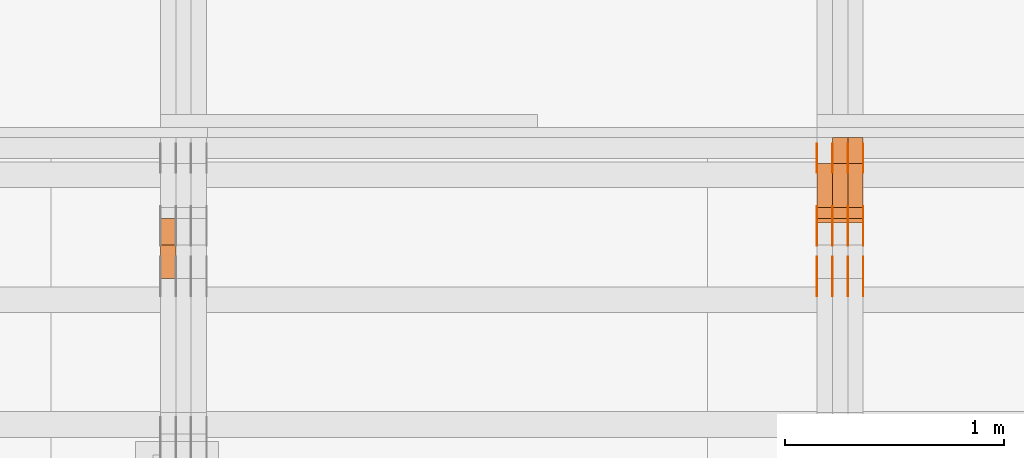
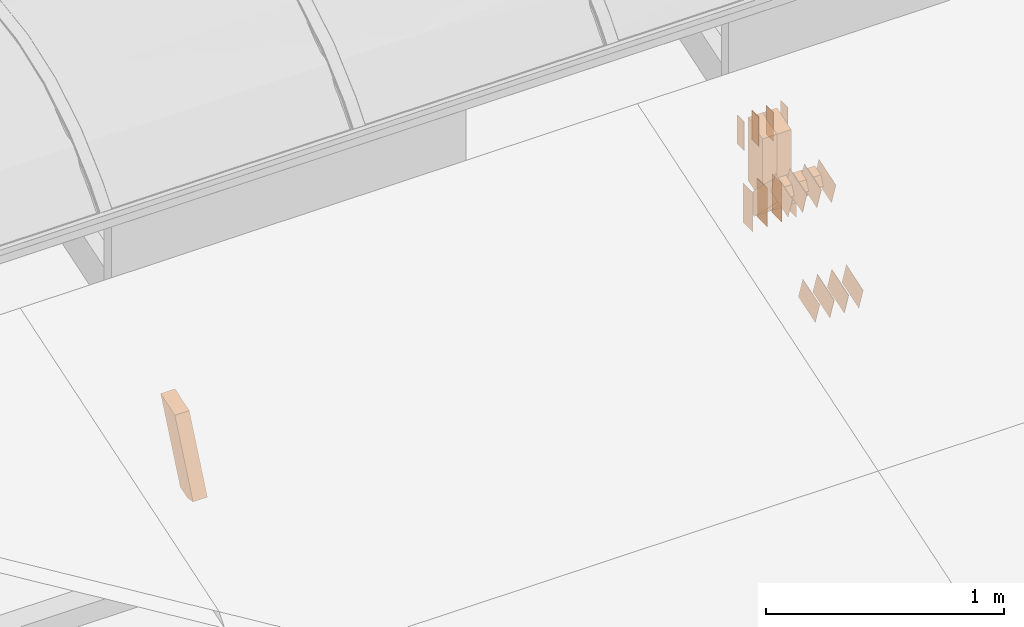
# One storey, part 157 of 385: 30 proxies.
"""IFC2X3 building model written with IfcOpenShell, lengths in millimetres."""

from ifc_helpers import new_model, entity, si_unit, converted_unit, derived_unit, direction, frame, frame_2d, origin, origin_2d_with_axis, place, context, subcontext, project, spatial, polyline, rectangle, outline, extrude, source, transform, mapped, material, type_object, type_shapes, element, save


model = new_model("IFC2X3")

# Units and contexts
model_context = context("Model", 3, precision=0.01, world=origin(), true_north=direction((6.12303176911189e-17, 1.0)))
body_context = subcontext(model_context, "Body", "Model", "MODEL_VIEW")
ifc_project = project(units=[si_unit("LENGTHUNIT", "METRE", prefix="MILLI"), si_unit("AREAUNIT", "SQUARE_METRE"), si_unit("VOLUMEUNIT", "CUBIC_METRE"), converted_unit("PLANEANGLEUNIT", "DEGREE", entity("IfcRatioMeasure", 0.0174532925199433), si_unit("PLANEANGLEUNIT", "RADIAN"), dimensions=[0, 0, 0, 0, 0, 0, 0]), si_unit("MASSUNIT", "GRAM", prefix="KILO"), derived_unit("MASSDENSITYUNIT", [(si_unit("MASSUNIT", "GRAM", prefix="KILO"), 1), (si_unit("LENGTHUNIT", "METRE"), -3)]), si_unit("TIMEUNIT", "SECOND"), si_unit("FREQUENCYUNIT", "HERTZ"), si_unit("THERMODYNAMICTEMPERATUREUNIT", "DEGREE_CELSIUS"), derived_unit("THERMALTRANSMITTANCEUNIT", [(si_unit("MASSUNIT", "GRAM", prefix="KILO"), 1), (si_unit("THERMODYNAMICTEMPERATUREUNIT", "KELVIN"), -1), (si_unit("TIMEUNIT", "SECOND"), -3)]), derived_unit("VOLUMETRICFLOWRATEUNIT", [(si_unit("LENGTHUNIT", "METRE"), 3), (si_unit("TIMEUNIT", "SECOND"), -1)]), si_unit("ELECTRICCURRENTUNIT", "AMPERE"), si_unit("ELECTRICVOLTAGEUNIT", "VOLT"), si_unit("POWERUNIT", "WATT"), si_unit("FORCEUNIT", "NEWTON", prefix="KILO"), si_unit("ILLUMINANCEUNIT", "LUX"), si_unit("LUMINOUSFLUXUNIT", "LUMEN"), si_unit("LUMINOUSINTENSITYUNIT", "CANDELA"), derived_unit("USERDEFINED", [(si_unit("MASSUNIT", "GRAM", prefix="KILO"), -1), (si_unit("LENGTHUNIT", "METRE"), -2), (si_unit("TIMEUNIT", "SECOND"), 3), (si_unit("LUMINOUSFLUXUNIT", "LUMEN"), 1)]), derived_unit("LINEARVELOCITYUNIT", [(si_unit("LENGTHUNIT", "METRE"), 1), (si_unit("TIMEUNIT", "SECOND"), -1)]), si_unit("PRESSUREUNIT", "PASCAL"), derived_unit("USERDEFINED", [(si_unit("LENGTHUNIT", "METRE"), -2), (si_unit("MASSUNIT", "GRAM", prefix="KILO"), 1), (si_unit("TIMEUNIT", "SECOND"), -2)])], contexts=[model_context])

# Site, building, storey
site_placement = place(None, origin())
site = spatial("IfcSite", under=ifc_project, at=site_placement, CompositionType="ELEMENT")
building_placement = place(site_placement, origin())
building = spatial("IfcBuilding", under=site, at=building_placement, CompositionType="ELEMENT")
storey_placement = place(building_placement, origin())
storey = spatial("IfcBuildingStorey", under=building, at=storey_placement, Name="Default", CompositionType="ELEMENT", Elevation=0.0)

# Proxies
ifc_material_1 = material(Name="IfcSurfaceStyle #346868")
building_element_proxy_type_1 = type_object("IfcBuildingElementProxyType", PredefinedType="NOTDEFINED", material=ifc_material_1)
shared_shape_1 = source(origin(), body_context, "Body", "SweptSolid", [
    extrude(rectangle(XDim=200.0, YDim=84.0, at=frame_2d((0.0, -7.105427357601e-15), x_axis=(1.0, 0.0))), frame((100.0, 42.0, 0.0), z_axis=(0.0, 0.0, 1.0), x_axis=(-1.0, 0.0, 0.0)), (0.0, 0.0, 1.0), 1.3),
])
type_shapes(building_element_proxy_type_1, [shared_shape_1])
proxy_1_placement = place(building_placement, frame((27386.3, 13702.0, 3651.4150390625), z_axis=(-1.0, 0.0, 0.0), x_axis=(0.0, 0.0, -1.0)))
element("IfcBuildingElementProxy", 1, at=proxy_1_placement, inside=storey, type_object=building_element_proxy_type_1, material=ifc_material_1, context=body_context, shape_type="MappedRepresentation", body=[
    mapped(shared_shape_1, transform((0.0, 0.0, 0.0), scale=1.0)),
])
ifc_material_2 = material(Name="IfcSurfaceStyle #346811")
building_element_proxy_type_2 = type_object("IfcBuildingElementProxyType", PredefinedType="NOTDEFINED", material=ifc_material_2)
shared_shape_2 = source(origin(), body_context, "Body", "SweptSolid", [
    extrude(rectangle(XDim=200.0, YDim=84.0, at=frame_2d((0.0, -7.105427357601e-15), x_axis=(1.0, 0.0))), frame((100.0, 42.0, 0.0), z_axis=(0.0, 0.0, 1.0), x_axis=(-1.0, 0.0, 0.0)), (0.0, 0.0, 1.0), 1.3),
])
type_shapes(building_element_proxy_type_2, [shared_shape_2])
proxy_2_placement = place(building_placement, frame((27315.0, 13702.0, 3651.4150390625), z_axis=(-1.0, 0.0, 0.0), x_axis=(0.0, 0.0, -1.0)))
element("IfcBuildingElementProxy", 2, at=proxy_2_placement, inside=storey, type_object=building_element_proxy_type_2, material=ifc_material_2, context=body_context, shape_type="MappedRepresentation", body=[
    mapped(shared_shape_2, transform((0.0, 0.0, 0.0), scale=1.0)),
])
ifc_material_3 = material(Name="IfcSurfaceStyle #346754")
building_element_proxy_type_3 = type_object("IfcBuildingElementProxyType", PredefinedType="NOTDEFINED", material=ifc_material_3)
shared_shape_3 = source(origin(), body_context, "Body", "SweptSolid", [
    extrude(rectangle(XDim=200.0, YDim=84.0, at=frame_2d((0.0, -7.105427357601e-15), x_axis=(1.0, 0.0))), frame((100.0, 42.0, 0.0), z_axis=(0.0, 0.0, 1.0), x_axis=(-1.0, 0.0, 0.0)), (0.0, 0.0, 1.0), 1.3),
])
type_shapes(building_element_proxy_type_3, [shared_shape_3])
proxy_3_placement = place(building_placement, frame((27316.3, 13702.0, 3651.4150390625), z_axis=(-1.0, 0.0, 0.0), x_axis=(0.0, 0.0, -1.0)))
element("IfcBuildingElementProxy", 3, at=proxy_3_placement, inside=storey, type_object=building_element_proxy_type_3, material=ifc_material_3, context=body_context, shape_type="MappedRepresentation", body=[
    mapped(shared_shape_3, transform((0.0, 0.0, 0.0), scale=1.0)),
])
ifc_material_4 = material(Name="IfcSurfaceStyle #346697")
building_element_proxy_type_4 = type_object("IfcBuildingElementProxyType", PredefinedType="NOTDEFINED", material=ifc_material_4)
shared_shape_4 = source(origin(), body_context, "Body", "SweptSolid", [
    extrude(rectangle(XDim=200.0, YDim=84.0, at=frame_2d((0.0, -7.105427357601e-15), x_axis=(1.0, 0.0))), frame((100.0, 42.0, 0.0), z_axis=(0.0, 0.0, 1.0), x_axis=(-1.0, 0.0, 0.0)), (0.0, 0.0, 1.0), 1.29999999999998),
])
type_shapes(building_element_proxy_type_4, [shared_shape_4])
proxy_4_placement = place(building_placement, frame((27245.0, 13702.0, 3651.4150390625), z_axis=(-1.0, 0.0, 0.0), x_axis=(0.0, 0.0, -1.0)))
element("IfcBuildingElementProxy", 4, at=proxy_4_placement, inside=storey, type_object=building_element_proxy_type_4, material=ifc_material_4, context=body_context, shape_type="MappedRepresentation", body=[
    mapped(shared_shape_4, transform((0.0, 0.0, 0.0), scale=1.0)),
])
ifc_material_5 = material(Name="IfcSurfaceStyle #346640")
building_element_proxy_type_5 = type_object("IfcBuildingElementProxyType", PredefinedType="NOTDEFINED", material=ifc_material_5)
shared_shape_5 = source(origin(), body_context, "Body", "SweptSolid", [
    extrude(rectangle(XDim=200.0, YDim=84.0, at=frame_2d((0.0, -7.105427357601e-15), x_axis=(1.0, 0.0))), frame((100.0, 42.0, 0.0), z_axis=(0.0, 0.0, 1.0), x_axis=(-1.0, 0.0, 0.0)), (0.0, 0.0, 1.0), 1.29999999999998),
])
type_shapes(building_element_proxy_type_5, [shared_shape_5])
proxy_5_placement = place(building_placement, frame((27246.3, 13702.0, 3651.4150390625), z_axis=(-1.0, 0.0, 0.0), x_axis=(0.0, 0.0, -1.0)))
element("IfcBuildingElementProxy", 5, at=proxy_5_placement, inside=storey, type_object=building_element_proxy_type_5, material=ifc_material_5, context=body_context, shape_type="MappedRepresentation", body=[
    mapped(shared_shape_5, transform((0.0, 0.0, 0.0), scale=1.0)),
])
ifc_material_6 = material(Name="IfcSurfaceStyle #346583")
building_element_proxy_type_6 = type_object("IfcBuildingElementProxyType", PredefinedType="NOTDEFINED", material=ifc_material_6)
shared_shape_6 = source(origin(), body_context, "Body", "SweptSolid", [
    extrude(rectangle(XDim=200.0, YDim=84.0, at=frame_2d((0.0, -7.105427357601e-15), x_axis=(1.0, 0.0))), frame((100.0, 42.0, 0.0), z_axis=(0.0, 0.0, 1.0), x_axis=(-1.0, 0.0, 0.0)), (0.0, 0.0, 1.0), 1.29999999999999),
])
type_shapes(building_element_proxy_type_6, [shared_shape_6])
proxy_6_placement = place(building_placement, frame((27175.0, 13702.0, 3651.4150390625), z_axis=(-1.0, 0.0, 0.0), x_axis=(0.0, 0.0, -1.0)))
element("IfcBuildingElementProxy", 6, at=proxy_6_placement, inside=storey, type_object=building_element_proxy_type_6, material=ifc_material_6, context=body_context, shape_type="MappedRepresentation", body=[
    mapped(shared_shape_6, transform((0.0, 0.0, 0.0), scale=1.0)),
])
ifc_material_7 = material(Name="IfcSurfaceStyle #346526")
building_element_proxy_type_7 = type_object("IfcBuildingElementProxyType", PredefinedType="NOTDEFINED", material=ifc_material_7)
shared_shape_7 = source(origin(), body_context, "Body", "SweptSolid", [
    extrude(outline(polyline([(-75.0003398116828, -59.9998507501386), (75.0003249421766, -59.9998507501386), (75.0003398116837, 59.9998507501387), (-75.0003249421775, 59.9998507501387), (-75.0003398116828, -59.9998507501386)])), frame((75.0003398116837, 60.0000773549637, 0.0), z_axis=(0.0, 0.0, 1.0), x_axis=(-1.0, 0.0, 0.0)), (0.0, 0.0, 1.0), 1.3),
])
type_shapes(building_element_proxy_type_7, [shared_shape_7])
proxy_7_placement = place(building_placement, frame((27386.3, 13054.73046875, 3417.8388671875), z_axis=(-1.0, 0.0, 0.0), x_axis=(0.0, 0.951056516295124, 0.309016994375039)))
element("IfcBuildingElementProxy", 7, at=proxy_7_placement, inside=storey, type_object=building_element_proxy_type_7, material=ifc_material_7, context=body_context, shape_type="MappedRepresentation", body=[
    mapped(shared_shape_7, transform((0.0, 0.0, 0.0), scale=1.0)),
])
ifc_material_8 = material(Name="IfcSurfaceStyle #346469")
building_element_proxy_type_8 = type_object("IfcBuildingElementProxyType", PredefinedType="NOTDEFINED", material=ifc_material_8)
shared_shape_8 = source(origin(), body_context, "Body", "SweptSolid", [
    extrude(outline(polyline([(-75.0003398116828, -59.9998507501386), (75.0003249421766, -59.9998507501386), (75.0003398116837, 59.9998507501387), (-75.0003249421775, 59.9998507501387), (-75.0003398116828, -59.9998507501386)])), frame((75.0003398116837, 60.0000773549637, 0.0), z_axis=(0.0, 0.0, 1.0), x_axis=(-1.0, 0.0, 0.0)), (0.0, 0.0, 1.0), 1.3),
])
type_shapes(building_element_proxy_type_8, [shared_shape_8])
proxy_8_placement = place(building_placement, frame((27315.0, 13054.73046875, 3417.8388671875), z_axis=(-1.0, 0.0, 0.0), x_axis=(0.0, 0.951056516295124, 0.309016994375039)))
element("IfcBuildingElementProxy", 8, at=proxy_8_placement, inside=storey, type_object=building_element_proxy_type_8, material=ifc_material_8, context=body_context, shape_type="MappedRepresentation", body=[
    mapped(shared_shape_8, transform((0.0, 0.0, 0.0), scale=1.0)),
])
ifc_material_9 = material(Name="IfcSurfaceStyle #346412")
building_element_proxy_type_9 = type_object("IfcBuildingElementProxyType", PredefinedType="NOTDEFINED", material=ifc_material_9)
shared_shape_9 = source(origin(), body_context, "Body", "SweptSolid", [
    extrude(outline(polyline([(-75.0003398116828, -59.9998507501386), (75.0003249421766, -59.9998507501386), (75.0003398116837, 59.9998507501387), (-75.0003249421775, 59.9998507501387), (-75.0003398116828, -59.9998507501386)])), frame((75.0003398116837, 60.0000773549637, 0.0), z_axis=(0.0, 0.0, 1.0), x_axis=(-1.0, 0.0, 0.0)), (0.0, 0.0, 1.0), 1.3),
])
type_shapes(building_element_proxy_type_9, [shared_shape_9])
proxy_9_placement = place(building_placement, frame((27316.3, 13054.73046875, 3417.8388671875), z_axis=(-1.0, 0.0, 0.0), x_axis=(0.0, 0.951056516295124, 0.309016994375039)))
element("IfcBuildingElementProxy", 9, at=proxy_9_placement, inside=storey, type_object=building_element_proxy_type_9, material=ifc_material_9, context=body_context, shape_type="MappedRepresentation", body=[
    mapped(shared_shape_9, transform((0.0, 0.0, 0.0), scale=1.0)),
])
ifc_material_10 = material(Name="IfcSurfaceStyle #346355")
building_element_proxy_type_10 = type_object("IfcBuildingElementProxyType", PredefinedType="NOTDEFINED", material=ifc_material_10)
shared_shape_10 = source(origin(), body_context, "Body", "SweptSolid", [
    extrude(outline(polyline([(-75.0003398116828, -59.9998507501386), (75.0003249421766, -59.9998507501386), (75.0003398116837, 59.9998507501387), (-75.0003249421775, 59.9998507501387), (-75.0003398116828, -59.9998507501386)])), frame((75.0003398116837, 60.0000773549637, 0.0), z_axis=(0.0, 0.0, 1.0), x_axis=(-1.0, 0.0, 0.0)), (0.0, 0.0, 1.0), 1.29999999999999),
])
type_shapes(building_element_proxy_type_10, [shared_shape_10])
proxy_10_placement = place(building_placement, frame((27245.0, 13054.73046875, 3417.8388671875), z_axis=(-1.0, 0.0, 0.0), x_axis=(0.0, 0.951056516295124, 0.309016994375039)))
element("IfcBuildingElementProxy", 10, at=proxy_10_placement, inside=storey, type_object=building_element_proxy_type_10, material=ifc_material_10, context=body_context, shape_type="MappedRepresentation", body=[
    mapped(shared_shape_10, transform((0.0, 0.0, 0.0), scale=1.0)),
])
ifc_material_11 = material(Name="IfcSurfaceStyle #346298")
building_element_proxy_type_11 = type_object("IfcBuildingElementProxyType", PredefinedType="NOTDEFINED", material=ifc_material_11)
shared_shape_11 = source(origin(), body_context, "Body", "SweptSolid", [
    extrude(outline(polyline([(-75.0003398116828, -59.9998507501386), (75.0003249421766, -59.9998507501386), (75.0003398116837, 59.9998507501387), (-75.0003249421775, 59.9998507501387), (-75.0003398116828, -59.9998507501386)])), frame((75.0003398116837, 60.0000773549637, 0.0), z_axis=(0.0, 0.0, 1.0), x_axis=(-1.0, 0.0, 0.0)), (0.0, 0.0, 1.0), 1.29999999999999),
])
type_shapes(building_element_proxy_type_11, [shared_shape_11])
proxy_11_placement = place(building_placement, frame((27246.3, 13054.73046875, 3417.8388671875), z_axis=(-1.0, 0.0, 0.0), x_axis=(0.0, 0.951056516295124, 0.309016994375039)))
element("IfcBuildingElementProxy", 11, at=proxy_11_placement, inside=storey, type_object=building_element_proxy_type_11, material=ifc_material_11, context=body_context, shape_type="MappedRepresentation", body=[
    mapped(shared_shape_11, transform((0.0, 0.0, 0.0), scale=1.0)),
])
ifc_material_12 = material(Name="IfcSurfaceStyle #346241")
building_element_proxy_type_12 = type_object("IfcBuildingElementProxyType", PredefinedType="NOTDEFINED", material=ifc_material_12)
shared_shape_12 = source(origin(), body_context, "Body", "SweptSolid", [
    extrude(outline(polyline([(-75.0003398116828, -59.9998507501386), (75.0003249421766, -59.9998507501386), (75.0003398116837, 59.9998507501387), (-75.0003249421775, 59.9998507501387), (-75.0003398116828, -59.9998507501386)])), frame((75.0003398116837, 60.0000773549637, 0.0), z_axis=(0.0, 0.0, 1.0), x_axis=(-1.0, 0.0, 0.0)), (0.0, 0.0, 1.0), 1.29999999999999),
])
type_shapes(building_element_proxy_type_12, [shared_shape_12])
proxy_12_placement = place(building_placement, frame((27175.0, 13054.73046875, 3417.8388671875), z_axis=(-1.0, 0.0, 0.0), x_axis=(0.0, 0.951056516295124, 0.309016994375039)))
element("IfcBuildingElementProxy", 12, at=proxy_12_placement, inside=storey, type_object=building_element_proxy_type_12, material=ifc_material_12, context=body_context, shape_type="MappedRepresentation", body=[
    mapped(shared_shape_12, transform((0.0, 0.0, 0.0), scale=1.0)),
])
ifc_material_13 = material(Name="IfcSurfaceStyle #338660")
building_element_proxy_type_13 = type_object("IfcBuildingElementProxyType", PredefinedType="NOTDEFINED", material=ifc_material_13)
shared_shape_13 = source(origin(), body_context, "Body", "SweptSolid", [
    extrude(outline(polyline([(-74.999875428623, -60.0000016373506), (74.9998605591059, -60.0000016373506), (74.9998754286239, 60.0000016373506), (-74.9998605591068, 60.0000016373506), (-74.999875428623, -60.0000016373506)])), frame((75.0002691827262, 60.0000190504561, 0.0), z_axis=(0.0, 0.0, 1.0), x_axis=(-1.0, 0.0, 0.0)), (0.0, 0.0, 1.0), 1.3),
])
type_shapes(building_element_proxy_type_13, [shared_shape_13])
proxy_13_placement = place(building_placement, frame((27386.3, 13285.0865109705, 3819.37496637467), z_axis=(-1.0, 0.0, 0.0), x_axis=(0.0, 0.951056516295154, 0.309016994374948)))
element("IfcBuildingElementProxy", 13, at=proxy_13_placement, inside=storey, type_object=building_element_proxy_type_13, material=ifc_material_13, context=body_context, shape_type="MappedRepresentation", body=[
    mapped(shared_shape_13, transform((0.0, 0.0, 0.0), scale=1.0)),
])
ifc_material_14 = material(Name="IfcSurfaceStyle #338603")
building_element_proxy_type_14 = type_object("IfcBuildingElementProxyType", PredefinedType="NOTDEFINED", material=ifc_material_14)
shared_shape_14 = source(origin(), body_context, "Body", "SweptSolid", [
    extrude(outline(polyline([(-74.999875428623, -60.0000016373506), (74.9998605591059, -60.0000016373506), (74.9998754286239, 60.0000016373506), (-74.9998605591068, 60.0000016373506), (-74.999875428623, -60.0000016373506)])), frame((75.0002691827262, 60.0000190504561, 0.0), z_axis=(0.0, 0.0, 1.0), x_axis=(-1.0, 0.0, 0.0)), (0.0, 0.0, 1.0), 1.3),
])
type_shapes(building_element_proxy_type_14, [shared_shape_14])
proxy_14_placement = place(building_placement, frame((27315.0, 13285.0865109705, 3819.37496637467), z_axis=(-1.0, 0.0, 0.0), x_axis=(0.0, 0.951056516295154, 0.309016994374948)))
element("IfcBuildingElementProxy", 14, at=proxy_14_placement, inside=storey, type_object=building_element_proxy_type_14, material=ifc_material_14, context=body_context, shape_type="MappedRepresentation", body=[
    mapped(shared_shape_14, transform((0.0, 0.0, 0.0), scale=1.0)),
])
ifc_material_15 = material(Name="IfcSurfaceStyle #338546")
building_element_proxy_type_15 = type_object("IfcBuildingElementProxyType", PredefinedType="NOTDEFINED", material=ifc_material_15)
shared_shape_15 = source(origin(), body_context, "Body", "SweptSolid", [
    extrude(outline(polyline([(-74.999875428623, -60.0000016373506), (74.9998605591059, -60.0000016373506), (74.9998754286239, 60.0000016373506), (-74.9998605591068, 60.0000016373506), (-74.999875428623, -60.0000016373506)])), frame((75.0002691827262, 60.0000190504561, 0.0), z_axis=(0.0, 0.0, 1.0), x_axis=(-1.0, 0.0, 0.0)), (0.0, 0.0, 1.0), 1.3),
])
type_shapes(building_element_proxy_type_15, [shared_shape_15])
proxy_15_placement = place(building_placement, frame((27316.3, 13285.0865109705, 3819.37496637467), z_axis=(-1.0, 0.0, 0.0), x_axis=(0.0, 0.951056516295154, 0.309016994374948)))
element("IfcBuildingElementProxy", 15, at=proxy_15_placement, inside=storey, type_object=building_element_proxy_type_15, material=ifc_material_15, context=body_context, shape_type="MappedRepresentation", body=[
    mapped(shared_shape_15, transform((0.0, 0.0, 0.0), scale=1.0)),
])
ifc_material_16 = material(Name="IfcSurfaceStyle #338489")
building_element_proxy_type_16 = type_object("IfcBuildingElementProxyType", PredefinedType="NOTDEFINED", material=ifc_material_16)
shared_shape_16 = source(origin(), body_context, "Body", "SweptSolid", [
    extrude(outline(polyline([(-74.999875428623, -60.0000016373506), (74.9998605591059, -60.0000016373506), (74.9998754286239, 60.0000016373506), (-74.9998605591068, 60.0000016373506), (-74.999875428623, -60.0000016373506)])), frame((75.0002691827262, 60.0000190504561, 0.0), z_axis=(0.0, 0.0, 1.0), x_axis=(-1.0, 0.0, 0.0)), (0.0, 0.0, 1.0), 1.29999999999999),
])
type_shapes(building_element_proxy_type_16, [shared_shape_16])
proxy_16_placement = place(building_placement, frame((27245.0, 13285.0865109705, 3819.37496637467), z_axis=(-1.0, 0.0, 0.0), x_axis=(0.0, 0.951056516295154, 0.309016994374948)))
element("IfcBuildingElementProxy", 16, at=proxy_16_placement, inside=storey, type_object=building_element_proxy_type_16, material=ifc_material_16, context=body_context, shape_type="MappedRepresentation", body=[
    mapped(shared_shape_16, transform((0.0, 0.0, 0.0), scale=1.0)),
])
ifc_material_17 = material(Name="IfcSurfaceStyle #338432")
building_element_proxy_type_17 = type_object("IfcBuildingElementProxyType", PredefinedType="NOTDEFINED", material=ifc_material_17)
shared_shape_17 = source(origin(), body_context, "Body", "SweptSolid", [
    extrude(outline(polyline([(-74.999875428623, -60.0000016373506), (74.9998605591059, -60.0000016373506), (74.9998754286239, 60.0000016373506), (-74.9998605591068, 60.0000016373506), (-74.999875428623, -60.0000016373506)])), frame((75.0002691827262, 60.0000190504561, 0.0), z_axis=(0.0, 0.0, 1.0), x_axis=(-1.0, 0.0, 0.0)), (0.0, 0.0, 1.0), 1.29999999999999),
])
type_shapes(building_element_proxy_type_17, [shared_shape_17])
proxy_17_placement = place(building_placement, frame((27246.3, 13285.0865109705, 3819.37496637467), z_axis=(-1.0, 0.0, 0.0), x_axis=(0.0, 0.951056516295154, 0.309016994374948)))
element("IfcBuildingElementProxy", 17, at=proxy_17_placement, inside=storey, type_object=building_element_proxy_type_17, material=ifc_material_17, context=body_context, shape_type="MappedRepresentation", body=[
    mapped(shared_shape_17, transform((0.0, 0.0, 0.0), scale=1.0)),
])
ifc_material_18 = material(Name="IfcSurfaceStyle #338375")
building_element_proxy_type_18 = type_object("IfcBuildingElementProxyType", PredefinedType="NOTDEFINED", material=ifc_material_18)
shared_shape_18 = source(origin(), body_context, "Body", "SweptSolid", [
    extrude(outline(polyline([(-74.999875428623, -60.0000016373506), (74.9998605591059, -60.0000016373506), (74.9998754286239, 60.0000016373506), (-74.9998605591068, 60.0000016373506), (-74.999875428623, -60.0000016373506)])), frame((75.0002691827262, 60.0000190504561, 0.0), z_axis=(0.0, 0.0, 1.0), x_axis=(-1.0, 0.0, 0.0)), (0.0, 0.0, 1.0), 1.29999999999999),
])
type_shapes(building_element_proxy_type_18, [shared_shape_18])
proxy_18_placement = place(building_placement, frame((27175.0, 13285.0865109705, 3819.37496637467), z_axis=(-1.0, 0.0, 0.0), x_axis=(0.0, 0.951056516295154, 0.309016994374948)))
element("IfcBuildingElementProxy", 18, at=proxy_18_placement, inside=storey, type_object=building_element_proxy_type_18, material=ifc_material_18, context=body_context, shape_type="MappedRepresentation", body=[
    mapped(shared_shape_18, transform((0.0, 0.0, 0.0), scale=1.0)),
])
ifc_material_19 = material(Name="IfcSurfaceStyle #337976")
building_element_proxy_type_19 = type_object("IfcBuildingElementProxyType", PredefinedType="NOTDEFINED", material=ifc_material_19)
shared_shape_19 = source(origin(), body_context, "Body", "SweptSolid", [
    extrude(rectangle(XDim=150.0, YDim=60.0, at=origin_2d_with_axis()), frame((75.0000705696166, 30.0, 0.0), z_axis=(0.0, 0.0, 1.0), x_axis=(-1.0, 0.0, 0.0)), (0.0, 0.0, 1.0), 1.3),
])
type_shapes(building_element_proxy_type_19, [shared_shape_19])
proxy_19_placement = place(building_placement, frame((27386.3, 13750.0, 3972.59919166337), z_axis=(-1.0, 0.0, 0.0), x_axis=(0.0, 0.0, -1.0)))
element("IfcBuildingElementProxy", 19, at=proxy_19_placement, inside=storey, type_object=building_element_proxy_type_19, material=ifc_material_19, context=body_context, shape_type="MappedRepresentation", body=[
    mapped(shared_shape_19, transform((0.0, 0.0, 0.0), scale=1.0)),
])
ifc_material_20 = material(Name="IfcSurfaceStyle #337919")
building_element_proxy_type_20 = type_object("IfcBuildingElementProxyType", PredefinedType="NOTDEFINED", material=ifc_material_20)
shared_shape_20 = source(origin(), body_context, "Body", "SweptSolid", [
    extrude(rectangle(XDim=150.0, YDim=60.0, at=origin_2d_with_axis()), frame((75.0000705696166, 30.0, 0.0), z_axis=(0.0, 0.0, 1.0), x_axis=(-1.0, 0.0, 0.0)), (0.0, 0.0, 1.0), 1.3),
])
type_shapes(building_element_proxy_type_20, [shared_shape_20])
proxy_20_placement = place(building_placement, frame((27315.0, 13750.0, 3972.59919166337), z_axis=(-1.0, 0.0, 0.0), x_axis=(0.0, 0.0, -1.0)))
element("IfcBuildingElementProxy", 20, at=proxy_20_placement, inside=storey, type_object=building_element_proxy_type_20, material=ifc_material_20, context=body_context, shape_type="MappedRepresentation", body=[
    mapped(shared_shape_20, transform((0.0, 0.0, 0.0), scale=1.0)),
])
ifc_material_21 = material(Name="IfcSurfaceStyle #337862")
building_element_proxy_type_21 = type_object("IfcBuildingElementProxyType", PredefinedType="NOTDEFINED", material=ifc_material_21)
shared_shape_21 = source(origin(), body_context, "Body", "SweptSolid", [
    extrude(rectangle(XDim=150.0, YDim=60.0, at=origin_2d_with_axis()), frame((75.0000705696166, 30.0, 0.0), z_axis=(0.0, 0.0, 1.0), x_axis=(-1.0, 0.0, 0.0)), (0.0, 0.0, 1.0), 1.3),
])
type_shapes(building_element_proxy_type_21, [shared_shape_21])
proxy_21_placement = place(building_placement, frame((27316.3, 13750.0, 3972.59919166337), z_axis=(-1.0, 0.0, 0.0), x_axis=(0.0, 0.0, -1.0)))
element("IfcBuildingElementProxy", 21, at=proxy_21_placement, inside=storey, type_object=building_element_proxy_type_21, material=ifc_material_21, context=body_context, shape_type="MappedRepresentation", body=[
    mapped(shared_shape_21, transform((0.0, 0.0, 0.0), scale=1.0)),
])
ifc_material_22 = material(Name="IfcSurfaceStyle #337805")
building_element_proxy_type_22 = type_object("IfcBuildingElementProxyType", PredefinedType="NOTDEFINED", material=ifc_material_22)
shared_shape_22 = source(origin(), body_context, "Body", "SweptSolid", [
    extrude(rectangle(XDim=150.0, YDim=60.0, at=origin_2d_with_axis()), frame((75.0000705696166, 30.0, 0.0), z_axis=(0.0, 0.0, 1.0), x_axis=(-1.0, 0.0, 0.0)), (0.0, 0.0, 1.0), 1.29999999999999),
])
type_shapes(building_element_proxy_type_22, [shared_shape_22])
proxy_22_placement = place(building_placement, frame((27245.0, 13750.0, 3972.59919166337), z_axis=(-1.0, 0.0, 0.0), x_axis=(0.0, 0.0, -1.0)))
element("IfcBuildingElementProxy", 22, at=proxy_22_placement, inside=storey, type_object=building_element_proxy_type_22, material=ifc_material_22, context=body_context, shape_type="MappedRepresentation", body=[
    mapped(shared_shape_22, transform((0.0, 0.0, 0.0), scale=1.0)),
])
ifc_material_23 = material(Name="IfcSurfaceStyle #337748")
building_element_proxy_type_23 = type_object("IfcBuildingElementProxyType", PredefinedType="NOTDEFINED", material=ifc_material_23)
shared_shape_23 = source(origin(), body_context, "Body", "SweptSolid", [
    extrude(rectangle(XDim=150.0, YDim=60.0, at=origin_2d_with_axis()), frame((75.0000705696166, 30.0, 0.0), z_axis=(0.0, 0.0, 1.0), x_axis=(-1.0, 0.0, 0.0)), (0.0, 0.0, 1.0), 1.29999999999999),
])
type_shapes(building_element_proxy_type_23, [shared_shape_23])
proxy_23_placement = place(building_placement, frame((27246.3, 13750.0, 3972.59919166337), z_axis=(-1.0, 0.0, 0.0), x_axis=(0.0, 0.0, -1.0)))
element("IfcBuildingElementProxy", 23, at=proxy_23_placement, inside=storey, type_object=building_element_proxy_type_23, material=ifc_material_23, context=body_context, shape_type="MappedRepresentation", body=[
    mapped(shared_shape_23, transform((0.0, 0.0, 0.0), scale=1.0)),
])
ifc_material_24 = material(Name="IfcSurfaceStyle #337691")
building_element_proxy_type_24 = type_object("IfcBuildingElementProxyType", PredefinedType="NOTDEFINED", material=ifc_material_24)
shared_shape_24 = source(origin(), body_context, "Body", "SweptSolid", [
    extrude(rectangle(XDim=150.0, YDim=60.0, at=origin_2d_with_axis()), frame((75.0000705696166, 30.0, 0.0), z_axis=(0.0, 0.0, 1.0), x_axis=(-1.0, 0.0, 0.0)), (0.0, 0.0, 1.0), 1.29999999999999),
])
type_shapes(building_element_proxy_type_24, [shared_shape_24])
proxy_24_placement = place(building_placement, frame((27175.0, 13750.0, 3972.59919166337), z_axis=(-1.0, 0.0, 0.0), x_axis=(0.0, 0.0, -1.0)))
element("IfcBuildingElementProxy", 24, at=proxy_24_placement, inside=storey, type_object=building_element_proxy_type_24, material=ifc_material_24, context=body_context, shape_type="MappedRepresentation", body=[
    mapped(shared_shape_24, transform((0.0, 0.0, 0.0), scale=1.0)),
])
ifc_material_25 = material(Name="IfcSurfaceStyle #328490")
building_element_proxy_type_25 = type_object("IfcBuildingElementProxyType", Name="T1-W49 328488", PredefinedType="NOTDEFINED", material=ifc_material_25)
shared_shape_25 = source(origin(), body_context, "Body", "SweptSolid", [
    extrude(outline(polyline([(-155.175867306415, -47.4997478409253), (152.310664695054, -47.4997478409253), (170.496756790954, -6.14570120142345e-05), (145.70957993751, 47.4998092979374), (-133.37808995724, 47.4998092979373), (-179.963044159863, -6.14570120298391e-05), (-155.175867306415, -47.4997478409253)])), frame((170.496756790954, 47.5001152140455, 0.0), z_axis=(0.0, 0.0, 1.0), x_axis=(-1.0, 0.0, 0.0)), (0.0, 0.0, 1.0), 70.0),
])
type_shapes(building_element_proxy_type_25, [shared_shape_25])
proxy_25_placement = place(building_placement, frame((27385.0, 13443.048524104, 3830.71841973934), z_axis=(-1.0, 0.0, 0.0), x_axis=(0.0, 0.713950095632063, -0.700196587357413)))
element("IfcBuildingElementProxy", 25, at=proxy_25_placement, inside=storey, type_object=building_element_proxy_type_25, material=ifc_material_25, Name="T1-W49", context=body_context, shape_type="MappedRepresentation", body=[
    mapped(shared_shape_25, transform((0.0, 0.0, 0.0), scale=1.0)),
])
ifc_material_26 = material(Name="IfcSurfaceStyle #328415")
building_element_proxy_type_26 = type_object("IfcBuildingElementProxyType", Name="T1-W49 328413", PredefinedType="NOTDEFINED", material=ifc_material_26)
shared_shape_26 = source(origin(), body_context, "Body", "SweptSolid", [
    extrude(outline(polyline([(-155.175867306415, -47.4997478409253), (152.310664695054, -47.4997478409253), (170.496756790954, -6.14570120142345e-05), (145.70957993751, 47.4998092979374), (-133.37808995724, 47.4998092979373), (-179.963044159863, -6.14570120298391e-05), (-155.175867306415, -47.4997478409253)])), frame((170.496756790954, 47.5001152140455, 0.0), z_axis=(0.0, 0.0, 1.0), x_axis=(-1.0, 0.0, 0.0)), (0.0, 0.0, 1.0), 70.0),
])
type_shapes(building_element_proxy_type_26, [shared_shape_26])
proxy_26_placement = place(building_placement, frame((27315.0, 13443.048524104, 3830.71841973934), z_axis=(-1.0, 0.0, 0.0), x_axis=(0.0, 0.713950095632063, -0.700196587357413)))
element("IfcBuildingElementProxy", 26, at=proxy_26_placement, inside=storey, type_object=building_element_proxy_type_26, material=ifc_material_26, Name="T1-W49", context=body_context, shape_type="MappedRepresentation", body=[
    mapped(shared_shape_26, transform((0.0, 0.0, 0.0), scale=1.0)),
])
ifc_material_27 = material(Name="IfcSurfaceStyle #328340")
building_element_proxy_type_27 = type_object("IfcBuildingElementProxyType", Name="T1-W49 328338", PredefinedType="NOTDEFINED", material=ifc_material_27)
shared_shape_27 = source(origin(), body_context, "Body", "SweptSolid", [
    extrude(outline(polyline([(-155.175867306415, -47.4997478409253), (152.310664695054, -47.4997478409253), (170.496756790954, -6.14570120142345e-05), (145.70957993751, 47.4998092979374), (-133.37808995724, 47.4998092979373), (-179.963044159863, -6.14570120298391e-05), (-155.175867306415, -47.4997478409253)])), frame((170.496756790954, 47.5001152140455, 0.0), z_axis=(0.0, 0.0, 1.0), x_axis=(-1.0, 0.0, 0.0)), (0.0, 0.0, 1.0), 70.0),
])
type_shapes(building_element_proxy_type_27, [shared_shape_27])
proxy_27_placement = place(building_placement, frame((27245.0, 13443.048524104, 3830.71841973934), z_axis=(-1.0, 0.0, 0.0), x_axis=(0.0, 0.713950095632063, -0.700196587357413)))
element("IfcBuildingElementProxy", 27, at=proxy_27_placement, inside=storey, type_object=building_element_proxy_type_27, material=ifc_material_27, Name="T1-W49", context=body_context, shape_type="MappedRepresentation", body=[
    mapped(shared_shape_27, transform((0.0, 0.0, 0.0), scale=1.0)),
])
ifc_material_28 = material(Name="IfcSurfaceStyle #328040")
building_element_proxy_type_28 = type_object("IfcBuildingElementProxyType", Name="T1-W1 328038", PredefinedType="NOTDEFINED", material=ifc_material_28)
shared_shape_28 = source(origin(), body_context, "Body", "SweptSolid", [
    extrude(outline(polyline([(-182.839782714844, -60.0), (143.849426269531, -60.0), (182.839660644531, 60.0), (-143.849304199219, 60.0), (-182.839782714844, -60.0)])), frame((182.839674685549, 60.0, 0.0), z_axis=(0.0, 0.0, 1.0), x_axis=(-1.0, 0.0, 0.0)), (0.0, 0.0, 1.0), 70.0),
])
type_shapes(building_element_proxy_type_28, [shared_shape_28])
proxy_28_placement = place(building_placement, frame((27385.0, 13660.0, 3551.41502502148), z_axis=(-1.0, 0.0, 0.0), x_axis=(0.0, 0.0, 1.0)))
element("IfcBuildingElementProxy", 28, at=proxy_28_placement, inside=storey, type_object=building_element_proxy_type_28, material=ifc_material_28, Name="T1-W1", context=body_context, shape_type="MappedRepresentation", body=[
    mapped(shared_shape_28, transform((0.0, 0.0, 0.0), scale=1.0)),
])
ifc_material_29 = material(Name="IfcSurfaceStyle #327983")
building_element_proxy_type_29 = type_object("IfcBuildingElementProxyType", Name="T1-W1 327981", PredefinedType="NOTDEFINED", material=ifc_material_29)
shared_shape_29 = source(origin(), body_context, "Body", "SweptSolid", [
    extrude(outline(polyline([(-182.839782714844, -60.0), (143.849426269531, -60.0), (182.839660644531, 60.0), (-143.849304199219, 60.0), (-182.839782714844, -60.0)])), frame((182.839674685549, 60.0, 0.0), z_axis=(0.0, 0.0, 1.0), x_axis=(-1.0, 0.0, 0.0)), (0.0, 0.0, 1.0), 70.0),
])
type_shapes(building_element_proxy_type_29, [shared_shape_29])
proxy_29_placement = place(building_placement, frame((27315.0, 13660.0, 3551.41502502148), z_axis=(-1.0, 0.0, 0.0), x_axis=(0.0, 0.0, 1.0)))
element("IfcBuildingElementProxy", 29, at=proxy_29_placement, inside=storey, type_object=building_element_proxy_type_29, material=ifc_material_29, Name="T1-W1", context=body_context, shape_type="MappedRepresentation", body=[
    mapped(shared_shape_29, transform((0.0, 0.0, 0.0), scale=1.0)),
])
ifc_material_30 = material(Name="IfcSurfaceStyle #292936")
building_element_proxy_type_30 = type_object("IfcBuildingElementProxyType", Name="T1-W42 292934", PredefinedType="NOTDEFINED", material=ifc_material_30)
shared_shape_30 = source(origin(), body_context, "Body", "SweptSolid", [
    extrude(outline(polyline([(-284.837590197601, -47.4997543607933), (129.95880168156, -47.4997543607933), (171.972324990451, 0.000162623346093338), (183.717007105413, 47.4996730491203), (-200.810543579822, 47.4996730491203), (-284.837590197601, -47.4997543607933)])), frame((183.717155718752, 47.4999821655365, 0.0), z_axis=(0.0, 0.0, 1.0), x_axis=(-1.0, 0.0, 0.0)), (0.0, 0.0, 1.0), 70.0),
])
type_shapes(building_element_proxy_type_30, [shared_shape_30])
proxy_30_placement = place(building_placement, frame((24245.0, 13135.8834463264, 3404.958483022), z_axis=(-1.0, 0.0, 0.0), x_axis=(0.0, 0.398630596470292, 0.917111578575769)))
element("IfcBuildingElementProxy", 30, at=proxy_30_placement, inside=storey, type_object=building_element_proxy_type_30, material=ifc_material_30, Name="T1-W42", context=body_context, shape_type="MappedRepresentation", body=[
    mapped(shared_shape_30, transform((0.0, 0.0, 0.0), scale=1.0)),
])

save(model, "model.ifc")
